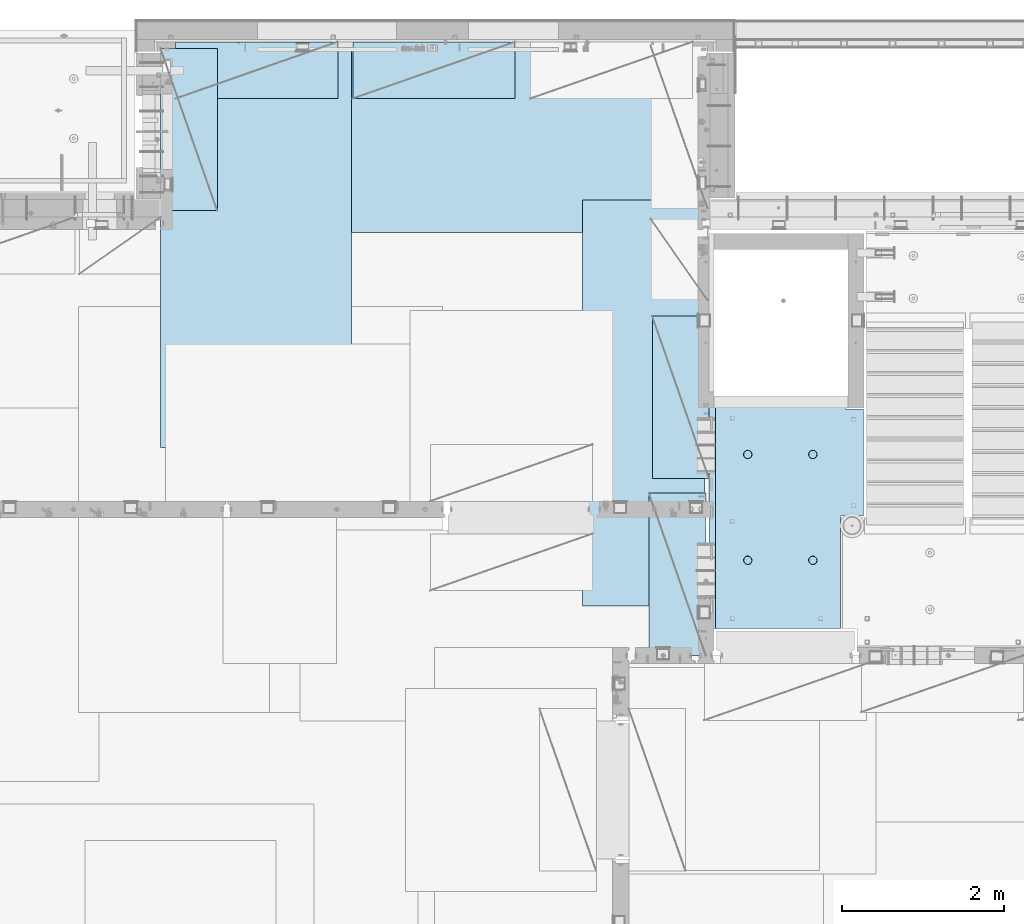
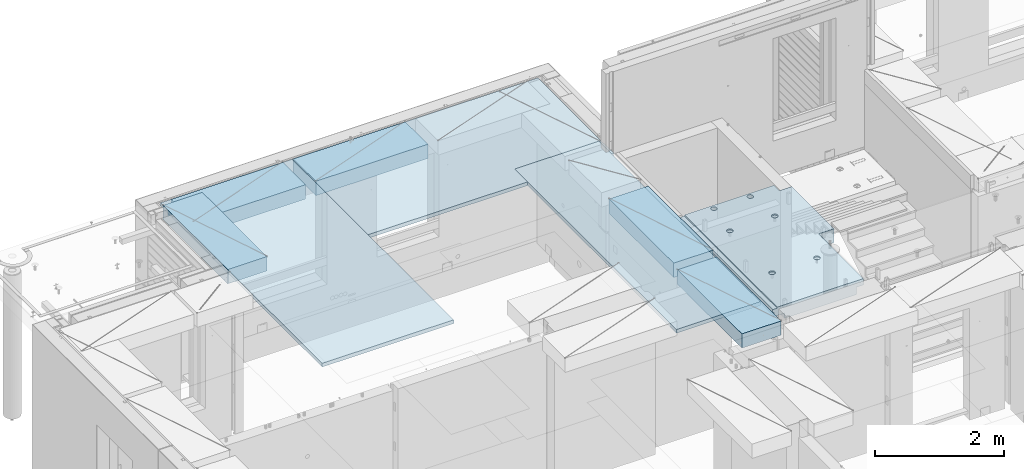
# One storey, part 207 of 350: 8 plates, 1 slab, 9 elements without a shape of their own.
"""IFC2X3 building model written with IfcOpenShell, lengths in millimetres."""

from ifc_helpers import new_model, si_unit, frame, origin_with_axes, place, context, subcontext, project, spatial, faceted_brep, material, type_object, element, aggregate, save


model = new_model("IFC2X3")

# Units and contexts
model_context = context("Model", 3, precision=1e-05, world=origin_with_axes())
body_context = subcontext(model_context, "Body", "Model", "MODEL_VIEW")
ifc_project = project(units=[si_unit("LENGTHUNIT", "METRE", prefix="MILLI"), si_unit("AREAUNIT", "SQUARE_METRE"), si_unit("VOLUMEUNIT", "CUBIC_METRE"), si_unit("MASSUNIT", "GRAM", prefix="KILO"), si_unit("TIMEUNIT", "SECOND"), si_unit("PLANEANGLEUNIT", "RADIAN"), si_unit("SOLIDANGLEUNIT", "STERADIAN"), si_unit("THERMODYNAMICTEMPERATUREUNIT", "DEGREE_CELSIUS"), si_unit("LUMINOUSINTENSITYUNIT", "LUMEN")], contexts=[model_context])

# Site, building, storey
site_placement = place(None, origin_with_axes())
site = spatial("IfcSite", under=ifc_project, at=site_placement, CompositionType="ELEMENT")
building_placement = place(site_placement, origin_with_axes())
building = spatial("IfcBuilding", under=site, at=building_placement, CompositionType="ELEMENT")
storey_placement = place(building_placement, origin_with_axes())
storey = spatial("IfcBuildingStorey", under=building, at=storey_placement, Name="2", CompositionType="ELEMENT", Elevation=0.0)

# Assembly, slab
assembly_1_placement = place(storey_placement, origin_with_axes())
assembly_1 = element("IfcElementAssembly", 1, at=assembly_1_placement, inside=storey, AssemblyPlace="NOTDEFINED", PredefinedType="REINFORCEMENT_UNIT")
ifc_material_1 = material(Name="CONCRETE/C25/30")
slab_type = type_object("IfcSlabType", PredefinedType="NOTDEFINED")
slab_placement = place(assembly_1_placement, frame((19370.0122708302, 15509.9992031236, 87620.0), z_axis=(-0.999999999999509, -9.91000000794397e-07, 0.0), x_axis=(-1.19799915409591e-06, 0.999999999999282, 0.0)))
slab = element("IfcSlab", 2, at=slab_placement, type_object=slab_type, material=ifc_material_1, PredefinedType="FLOOR", context=body_context, shape_type="Brep", body=[
    faceted_brep([(0.00270234311210515, 30.0, 1600.01636881603), (700.003686840937, 30.0, 1600.01632471597), (700.003459213352, 30.0, 1410.0099940095), (0.0034592138545122, 30.0, 1410.0108326095), (700.003459213352, 130.0, 1410.0099940095), (700.003686840937, 50.0008724475629, 1600.01632471597), (700.003710793628, 50.0008724475629, 1620.01159965654), (700.003710793628, 130.0, 1620.01159965654), (0.00238143379829125, 130.0, 1410.01083261132), (2149.99368684227, 30.0, 1600.01623336659), (2149.99345921271, 30.0, 1410.00825692148), (1649.99345921307, 30.0, 1410.00885592148), (1649.99368684195, 30.0, 1600.01626486659), (1390.00354003907, -130.0, -1.24055077321827e-09), (0.0, -130.0, -3.63797880709171e-12), (0.0, -10.0, 0.0), (1390.00503210942, -10.0000000000582, -8.29459168016911e-10), (0.00020267313993827, -10.0000000000582, 119.999691808891), (1390.0049992294, -10.0000000000582, 120.000072670202), (1390.0049992294, 129.999999999942, 120.000072670202), (0.000202673141757259, 130.0, 119.999691808891), (1390.00354003907, 130.0, -1.24055077321827e-09), (1390.00305175782, -130.0, -279.993591308594), (1390.00350516116, 130.0, -19.9999273271205), (1390.00305175782, 130.0, -279.993591308594), (2704.99731446005, 130.0, -279.993808230734), (2704.99731446008, -130.0, -279.993645464809), (2704.99757802008, 130.0, -59.9936454649687), (2704.99757802008, -130.000000000015, -59.9936454649687), (2869.99708830242, -130.0, -59.9938431343799), (2869.99708830242, 130.0, -59.9938431343799), (2869.99538188219, 50.0011350165441, 1600.0161880065), (2869.99536132813, 50.0011350165441, 1620.01123046875), (2149.99371079323, 50.0010478963522, 1620.01135296499), (2149.99368684227, 50.0010478963377, 1600.0162333666), (2869.99536132813, -109.999999999985, 1620.01123046875), (0.00273611420016096, -109.999999999985, 1620.01171875), (0.0026009984267148, -109.999999999985, 1540.01171889739), (2869.99544356416, -109.999999999985, 1540.01180212718), (2869.99536132813, -49.9988649834559, 1620.01123046875), (0.00273611420016096, -49.9992122525582, 1620.01171875), (2869.99538188219, -49.9988649834559, 1600.01618800648), (0.00270234311210515, -49.9992122525582, 1600.01636881602), (2869.99544356416, -129.999999999985, 1540.01180212718), (2869.99536132813, 130.0, 1620.01123046875), (2149.99371079323, 130.0, 1620.01135296499), (2149.99345921271, 130.0, 1410.00825692148), (1649.99345921307, 130.0, 1410.00885592148), (1649.99371079351, 130.0, 1620.01143803163), (1649.99371079351, 50.0009873963572, 1620.01143803163), (1649.99368684195, 50.0009873963427, 1600.0162648666), (0.0026009984267148, -130.0, 1540.01171889739), (858.080152798024, -110.0, 1097.45747495204), (872.018574202059, -110.0, 1104.55943434983), (883.080174557956, -110.0, 1115.62100820216), (890.182167352177, -110.0, 1129.55941258986), (892.62936004754, -110.0, 1145.01025937688), (890.182204372413, -110.0, 1160.46111202734), (883.08024497463, -110.0, 1174.39953343137), (872.018671122296, -110.0, 1185.46113378727), (858.080266734594, -110.0, 1192.56312658148), (842.629419947572, -110.0, 1195.01031927685), (827.178567297122, -110.0, 1192.56316360172), (813.240145893089, -110.0, 1185.46120420394), (802.178545537192, -110.0, 1174.3996303516), (795.076552742968, -110.0, 1160.46122596391), (792.629360047609, -110.0, 1145.01037917688), (795.076515722732, -110.0, 1129.55952652643), (802.178475120518, -110.0, 1115.62110512239), (813.240048972852, -110.0, 1104.5595047665), (827.178453360551, -110.0, 1097.45751197228), (842.629300147573, -110.0, 1095.01031927692), (858.782461559409, -130.0, 1095.29598202818), (842.629297424846, -130.0, 1092.73759200419), (873.354447572716, -130.0, 1102.72075776224), (884.918847944788, -130.0, 1114.28513042604), (892.343658593298, -130.0, 1128.85709864954), (894.902087320264, -130.0, 1145.01025665415), (892.34369729627, -130.0, 1161.16342078871), (884.918921562221, -130.0, 1175.73540680203), (873.354548898418, -130.0, 1187.29980717409), (858.782580674915, -130.0, 1194.72461782261), (842.629422670299, -130.0, 1197.28304654957), (826.476258535738, -130.0, 1194.72465652558), (811.90427252243, -130.0, 1187.29988079152), (800.339872150354, -130.0, 1175.73550812773), (792.915061501848, -130.0, 1161.16353990422), (790.356632774883, -130.0, 1145.01038189961), (792.915022798874, -130.0, 1128.85721776505), (800.339798532925, -130.0, 1114.28523175174), (811.904171196727, -130.0, 1102.72083137967), (826.476139420232, -130.0, 1095.29602073116), (858.08015281103, -110.0, 296.158841760913), (872.018574215066, -110.0, 303.2608011587), (883.080174570961, -110.0, 314.322375011034), (890.182167365187, -110.0, 328.26077939873), (892.629360060546, -110.0, 343.711626185755), (890.182204385423, -110.0, 359.162478836206), (883.080244987636, -110.0, 373.100900240239), (872.018671135302, -110.0, 384.16250059614), (858.0802667476, -110.0, 391.264493390358), (842.62941996058, -110.0, 393.711686085717), (827.178567310128, -110.0, 391.264530410594), (813.240145906095, -110.0, 384.16257101281), (802.178545550198, -110.0, 373.100997160473), (795.076552755974, -110.0, 359.162592772776), (792.629360060615, -110.0, 343.711745985755), (795.076515735738, -110.0, 328.2608933353), (802.178475133525, -110.0, 314.322471931268), (813.240048985859, -110.0, 303.26087157537), (827.178453373557, -110.0, 296.158878781149), (842.629300160579, -110.0, 293.71168608579), (858.782461572417, -130.0, 293.997348837052), (842.629297437852, -130.0, 291.438958813062), (873.354447585723, -130.0, 301.422124571109), (884.918847957797, -130.0, 312.98649723491), (892.343658606304, -130.0, 327.558465458413), (894.90208733327, -130.0, 343.711623463027), (892.343697309276, -130.0, 359.864787597588), (884.918921575227, -130.0, 374.436773610898), (873.354548911424, -130.0, 386.001173982968), (858.782580687921, -130.0, 393.425984631478), (842.629422683307, -130.0, 395.984413358441), (826.476258548744, -130.0, 393.426023334454), (811.904272535436, -130.0, 386.001247600398), (800.339872163362, -130.0, 374.4368749366), (792.915061514856, -130.0, 359.864906713094), (790.356632787889, -130.0, 343.711748708483), (792.915022811882, -130.0, 327.558584573919), (800.339798545931, -130.0, 312.986598560612), (811.904171209735, -130.0, 301.422198188538), (826.47613943324, -130.0, 293.997387540028), (2162.44895919675, -110.0, 1097.45754446905), (2176.38738060079, -110.0, 1104.55950386684), (2187.44898095669, -110.0, 1115.62107771917), (2194.55097375091, -110.0, 1129.55948210687), (2196.99816644627, -110.0, 1145.0103288939), (2194.55101077115, -110.0, 1160.46118154435), (2187.44905137336, -110.0, 1174.39960294838), (2176.38747752102, -110.0, 1185.46120330428), (2162.44907313332, -110.0, 1192.5631960985), (2146.9982263463, -110.0, 1195.01038879386), (2131.54737369585, -110.0, 1192.56323311873), (2117.60895229182, -110.0, 1185.46127372095), (2106.54735193592, -110.0, 1174.39969986862), (2099.4453591417, -110.0, 1160.46129548092), (2096.99816644634, -110.0, 1145.01044869389), (2099.44532212146, -110.0, 1129.55959604344), (2106.54728151925, -110.0, 1115.62117463941), (2117.60885537159, -110.0, 1104.55957428351), (2131.54725975928, -110.0, 1097.45758148929), (2146.9981065463, -110.0, 1095.01038879393), (2163.15126795814, -130.0, 1095.2960515452), (2146.99810382357, -130.0, 1092.73766152121), (2177.72325397145, -130.0, 1102.72082727925), (2189.28765434352, -130.0, 1114.28519994305), (2196.71246499203, -130.0, 1128.85716816655), (2199.27089371899, -130.0, 1145.01032617117), (2196.71250369501, -130.0, 1161.16349030573), (2189.28772796095, -130.0, 1175.73547631904), (2177.72335529715, -130.0, 1187.29987669111), (2163.15138707365, -130.0, 1194.72468733962), (2146.99822906903, -130.0, 1197.28311606658), (2130.84506493447, -130.0, 1194.72472604259), (2116.27307892116, -130.0, 1187.29995030854), (2104.70867854909, -130.0, 1175.73557764474), (2097.28386790058, -130.0, 1161.16360942123), (2094.72543917361, -130.0, 1145.01045141662), (2097.2838291976, -130.0, 1128.85728728206), (2104.70860493166, -130.0, 1114.28530126875), (2116.27297759546, -130.0, 1102.72090089668), (2130.84494581896, -130.0, 1095.29609024817), (2162.44895913772, -110.0, 296.158911320326), (2176.38738054176, -110.0, 303.260870718113), (2187.44898089765, -110.0, 314.322444570447), (2194.55097369188, -110.0, 328.260848958147), (2196.99816638724, -110.0, 343.711695745169), (2194.55101071211, -110.0, 359.162548395623), (2187.44905131433, -110.0, 373.100969799652), (2176.38747746199, -110.0, 384.162570155553), (2162.44907307429, -110.0, 391.264562949771), (2146.99822628727, -110.0, 393.711755645134), (2131.54737363682, -110.0, 391.264599970007), (2117.60895223279, -110.0, 384.162640572227), (2106.54735187689, -110.0, 373.10106671989), (2099.44535908267, -110.0, 359.162662332194), (2096.99816638731, -110.0, 343.711815545168), (2099.44532206243, -110.0, 328.260962894718), (2106.54728146021, -110.0, 314.322541490685), (2117.60885531255, -110.0, 303.260941134788), (2131.54725970025, -110.0, 296.158948340562), (2146.99810648727, -110.0, 293.711755645207), (2163.15126789911, -130.0, 293.997418396466), (2146.99810376454, -130.0, 291.439028372479), (2177.72325391241, -130.0, 301.422194130522), (2189.28765428449, -130.0, 312.986566794323), (2196.712464933, -130.0, 327.558535017826), (2199.27089365996, -130.0, 343.711693022444), (2196.71250363597, -130.0, 359.864857157001), (2189.28772790192, -130.0, 374.436843170311), (2177.72335523811, -130.0, 386.001243542381), (2163.15138701461, -130.0, 393.426054190892), (2146.99822901, -130.0, 395.984482917858), (2130.84506487544, -130.0, 393.426092893867), (2116.27307886213, -130.0, 386.001317159811), (2104.70867849006, -130.0, 374.436944496014), (2097.28386784155, -130.0, 359.864976272507), (2094.72543911458, -130.0, 343.711818267897), (2097.28382913857, -130.0, 327.558654133332), (2104.70860487263, -130.0, 312.986668120026), (2116.27297753642, -130.0, 301.422267747952), (2130.84494575993, -130.0, 293.997457099442), (2805.44844412025, -130.0, 362.453408379821), (2805.44844412025, 130.0, 362.453408379821), (2789.9975914698, 130.0, 360.006252704694), (2789.9975914698, -130.0, 360.006252704694), (2819.38686552428, -130.0, 369.555367777604), (2819.38686552428, 130.0, 369.555367777604), (2830.44846588018, -130.0, 380.616941629942), (2830.44846588018, 130.0, 380.616941629942), (2837.5504586744, -130.0, 394.555346017638), (2837.5504586744, 130.0, 394.555346017638), (2839.99765136976, -130.0, 410.006192804663), (2839.99765136976, 130.0, 410.006192804663), (2837.55049569464, -130.0, 425.457045455114), (2837.55049569464, 130.0, 425.457045455114), (2830.44853629686, -130.0, 439.395466859147), (2830.44853629686, 130.0, 439.395466859147), (2819.38696244451, -130.0, 450.457067215044), (2819.38696244451, 130.0, 450.457067215044), (2805.44855805682, -130.0, 457.559060009266), (2805.44855805682, 130.0, 457.559060009266), (2789.9977112698, -130.0, 460.006252704625), (2789.9977112698, 130.0, 460.006252704625), (2774.54685861935, -130.0, 457.559097029502), (2774.54685861935, 130.0, 457.559097029502), (2760.60843721531, -130.0, 450.457137631718), (2760.60843721531, 130.0, 450.457137631718), (2749.54683685942, -130.0, 439.395563779381), (2749.54683685942, 130.0, 439.395563779381), (2742.44484406519, -130.0, 425.457159391684), (2742.44484406519, 130.0, 425.457159391684), (2739.99765136983, -130.0, 410.006312604663), (2739.99765136983, 130.0, 410.006312604663), (2742.44480704495, -130.0, 394.555459954208), (2742.44480704495, 130.0, 394.555459954208), (2749.54676644274, -130.0, 380.617038550175), (2749.54676644274, 130.0, 380.617038550175), (2760.60834029508, -130.0, 369.555438194278), (2760.60834029508, 130.0, 369.555438194278), (2774.54674468278, -130.0, 362.453445400057), (2774.54674468278, 130.0, 362.453445400057), (2760.60911899507, -130.0, 1019.55543819397), (2749.54754514274, -130.0, 1030.61703854987), (2742.44558574495, -130.0, 1044.5554599539), (2739.99843006983, -130.0, 1060.00631260435), (2742.44562276519, -130.0, 1075.45715939137), (2749.54761555942, -130.0, 1089.39556377907), (2760.60921591531, -130.0, 1100.45713763141), (2774.54763731935, -130.0, 1107.55909702919), (2789.9984899698, -130.0, 1110.00625270432), (2805.44933675682, -130.0, 1107.55906000896), (2819.38774114452, -130.0, 1100.45706721473), (2830.44931499685, -130.0, 1089.39546685884), (2837.55127439463, -130.0, 1075.4570454548), (2839.99843006976, -130.0, 1060.00619280435), (2837.5512373744, -130.0, 1044.55534601733), (2830.44924458018, -130.0, 1030.61694162963), (2819.38764422428, -130.0, 1019.55536777729), (2805.44922282025, -130.0, 1012.45340837951), (2789.9983701698, -130.0, 1010.00625270438), (2774.54752338277, -130.0, 1012.45344539975), (2819.38764422428, 130.0, 1019.55536777729), (2805.44922282025, 130.0, 1012.45340837951), (2830.44924458018, 130.0, 1030.61694162963), (2837.5512373744, 130.0, 1044.55534601733), (2839.99843006976, 130.0, 1060.00619280435), (2837.55127439463, 130.0, 1075.4570454548), (2830.44931499685, 130.0, 1089.39546685884), (2819.38774114452, 130.0, 1100.45706721473), (2805.44933675682, 130.0, 1107.55906000896), (2789.9984899698, 130.0, 1110.00625270432), (2774.54763731935, 130.0, 1107.55909702919), (2760.60921591531, 130.0, 1100.45713763141), (2749.54761555942, 130.0, 1089.39556377907), (2742.44562276519, 130.0, 1075.45715939137), (2739.99843006983, 130.0, 1060.00631260435), (2742.44558574495, 130.0, 1044.5554599539), (2749.54754514274, 130.0, 1030.61703854987), (2760.60911899507, 130.0, 1019.55543819397), (2774.54752338277, 130.0, 1012.45344539975), (2789.9983701698, 130.0, 1010.00625270438)], [[[0, 1, 2, 3]], [[4, 2, 1, 5, 6, 7]], [[8, 3, 2, 4]], [[9, 10, 11, 12]], [[13, 14, 15, 16]], [[15, 17, 18, 16]], [[19, 18, 17, 20]], [[16, 18, 19, 21]], [[22, 13, 16, 21, 23, 24]], [[22, 24, 25, 26]], [[26, 25, 27, 28]], [[29, 28, 27, 30]], [[31, 32, 33, 34]], [[35, 36, 37, 38]], [[36, 35, 39, 40]], [[41, 42, 40, 39]], [[35, 38, 43, 29, 30, 44, 32, 31, 41, 39]], [[32, 44, 45, 33]], [[46, 10, 9, 34, 33, 45]], [[47, 11, 10, 46]], [[48, 49, 50, 12, 11, 47]], [[49, 48, 7, 6]], [[50, 49, 6, 5]], [[42, 41, 31, 34, 9, 12, 50, 5, 1, 0]], [[20, 17, 15, 14, 51, 37, 36, 40, 42, 0, 3, 8]], [[43, 38, 37, 51]], [[52, 53, 54, 55, 56, 57, 58, 59, 60, 61, 62, 63, 64, 65, 66, 67, 68, 69, 70, 71]], [[72, 52, 71, 73]], [[74, 53, 52, 72]], [[75, 54, 53, 74]], [[76, 55, 54, 75]], [[77, 56, 55, 76]], [[78, 57, 56, 77]], [[79, 58, 57, 78]], [[80, 59, 58, 79]], [[81, 60, 59, 80]], [[82, 61, 60, 81]], [[83, 62, 61, 82]], [[84, 63, 62, 83]], [[85, 64, 63, 84]], [[86, 65, 64, 85]], [[87, 66, 65, 86]], [[88, 67, 66, 87]], [[89, 68, 67, 88]], [[90, 69, 68, 89]], [[91, 70, 69, 90]], [[73, 71, 70, 91]], [[92, 93, 94, 95, 96, 97, 98, 99, 100, 101, 102, 103, 104, 105, 106, 107, 108, 109, 110, 111]], [[112, 92, 111, 113]], [[114, 93, 92, 112]], [[115, 94, 93, 114]], [[116, 95, 94, 115]], [[117, 96, 95, 116]], [[118, 97, 96, 117]], [[119, 98, 97, 118]], [[120, 99, 98, 119]], [[121, 100, 99, 120]], [[122, 101, 100, 121]], [[123, 102, 101, 122]], [[124, 103, 102, 123]], [[125, 104, 103, 124]], [[126, 105, 104, 125]], [[127, 106, 105, 126]], [[128, 107, 106, 127]], [[129, 108, 107, 128]], [[130, 109, 108, 129]], [[131, 110, 109, 130]], [[113, 111, 110, 131]], [[132, 133, 134, 135, 136, 137, 138, 139, 140, 141, 142, 143, 144, 145, 146, 147, 148, 149, 150, 151]], [[152, 132, 151, 153]], [[154, 133, 132, 152]], [[155, 134, 133, 154]], [[156, 135, 134, 155]], [[157, 136, 135, 156]], [[158, 137, 136, 157]], [[159, 138, 137, 158]], [[160, 139, 138, 159]], [[161, 140, 139, 160]], [[162, 141, 140, 161]], [[163, 142, 141, 162]], [[164, 143, 142, 163]], [[165, 144, 143, 164]], [[166, 145, 144, 165]], [[167, 146, 145, 166]], [[168, 147, 146, 167]], [[169, 148, 147, 168]], [[170, 149, 148, 169]], [[171, 150, 149, 170]], [[153, 151, 150, 171]], [[172, 173, 174, 175, 176, 177, 178, 179, 180, 181, 182, 183, 184, 185, 186, 187, 188, 189, 190, 191]], [[192, 172, 191, 193]], [[194, 173, 172, 192]], [[195, 174, 173, 194]], [[196, 175, 174, 195]], [[197, 176, 175, 196]], [[198, 177, 176, 197]], [[199, 178, 177, 198]], [[200, 179, 178, 199]], [[201, 180, 179, 200]], [[202, 181, 180, 201]], [[203, 182, 181, 202]], [[204, 183, 182, 203]], [[205, 184, 183, 204]], [[206, 185, 184, 205]], [[207, 186, 185, 206]], [[208, 187, 186, 207]], [[209, 188, 187, 208]], [[210, 189, 188, 209]], [[211, 190, 189, 210]], [[193, 191, 190, 211]], [[212, 213, 214, 215]], [[216, 217, 213, 212]], [[218, 219, 217, 216]], [[220, 221, 219, 218]], [[222, 223, 221, 220]], [[224, 225, 223, 222]], [[226, 227, 225, 224]], [[228, 229, 227, 226]], [[230, 231, 229, 228]], [[232, 233, 231, 230]], [[234, 235, 233, 232]], [[236, 237, 235, 234]], [[238, 239, 237, 236]], [[240, 241, 239, 238]], [[242, 243, 241, 240]], [[244, 245, 243, 242]], [[246, 247, 245, 244]], [[248, 249, 247, 246]], [[250, 251, 249, 248]], [[215, 214, 251, 250]], [[14, 13, 22, 26, 28, 29, 43, 51], [252, 253, 254, 255, 256, 257, 258, 259, 260, 261, 262, 263, 264, 265, 266, 267, 268, 269, 270, 271], [248, 246, 244, 242, 240, 238, 236, 234, 232, 230, 228, 226, 224, 222, 220, 218, 216, 212, 215, 250], [210, 209, 208, 207, 206, 205, 204, 203, 202, 201, 200, 199, 198, 197, 196, 195, 194, 192, 193, 211], [170, 169, 168, 167, 166, 165, 164, 163, 162, 161, 160, 159, 158, 157, 156, 155, 154, 152, 153, 171], [130, 129, 128, 127, 126, 125, 124, 123, 122, 121, 120, 119, 118, 117, 116, 115, 114, 112, 113, 131], [90, 89, 88, 87, 86, 85, 84, 83, 82, 81, 80, 79, 78, 77, 76, 75, 74, 72, 73, 91]], [[268, 272, 273, 269]], [[267, 274, 272, 268]], [[266, 275, 274, 267]], [[265, 276, 275, 266]], [[264, 277, 276, 265]], [[263, 278, 277, 264]], [[262, 279, 278, 263]], [[261, 280, 279, 262]], [[260, 281, 280, 261]], [[259, 282, 281, 260]], [[258, 283, 282, 259]], [[257, 284, 283, 258]], [[256, 285, 284, 257]], [[255, 286, 285, 256]], [[254, 287, 286, 255]], [[253, 288, 287, 254]], [[252, 289, 288, 253]], [[271, 290, 289, 252]], [[270, 291, 290, 271]], [[269, 273, 291, 270]], [[48, 47, 46, 45, 44, 30, 27, 25, 24, 23, 21, 19, 20, 8, 4, 7], [272, 274, 275, 276, 277, 278, 279, 280, 281, 282, 283, 284, 285, 286, 287, 288, 289, 290, 291, 273], [217, 219, 221, 223, 225, 227, 229, 231, 233, 235, 237, 239, 241, 243, 245, 247, 249, 251, 214, 213]]]),
])
aggregate(assembly_1, [slab])

# Assembly, plate
assembly_2_placement = place(storey_placement, origin_with_axes())
assembly_2 = element("IfcElementAssembly", 3, at=assembly_2_placement, inside=storey, Name="Steel Assembly", AssemblyPlace="NOTDEFINED", PredefinedType="NOTDEFINED")
ifc_material_2 = material()
plate_type_1 = type_object("IfcPlateType", PredefinedType="NOTDEFINED")
plate_1_placement = place(assembly_2_placement, frame((12729.9998779297, 22740.0009765625, 87695.1), z_axis=(1.0, 0.0, 0.0), x_axis=(0.0, -1.0, 0.0)))
plate_1 = element("IfcPlate", 4, at=plate_1_placement, type_object=plate_type_1, material=ifc_material_2, context=body_context, shape_type="Brep", body=[
    faceted_brep([(0.0, -35.0, 0.0), (0.0, -35.0, 5000.0), (0.0, 35.0, 5000.0), (0.0, 35.0, 0.0), (2349.99951171875, -35.0, 5000.0), (2349.99951171875, 35.0, 5000.0), (2350.0, -35.0, 0.0), (2350.0, 35.0, 0.0)], [[[0, 1, 2, 3]], [[1, 4, 5, 2]], [[4, 6, 7, 5]], [[6, 0, 3, 7]], [[5, 7, 3, 2]], [[6, 4, 1, 0]]]),
])
aggregate(assembly_2, [plate_1])

assembly_3_placement = place(storey_placement, origin_with_axes())
assembly_3 = element("IfcElementAssembly", 5, at=assembly_3_placement, inside=storey, Name="Steel Assembly", AssemblyPlace="NOTDEFINED", PredefinedType="NOTDEFINED")
plate_2_placement = place(assembly_3_placement, frame((13340.0, 22740.0, 87695.1), z_axis=(0.0, -1.0, 0.0), x_axis=(-1.0, 3.00000001838171e-08, 0.0)))
plate_2 = element("IfcPlate", 6, at=plate_2_placement, type_object=plate_type_1, material=ifc_material_2, context=body_context, shape_type="Brep", body=[
    faceted_brep([(0.0, -35.0, 0.0), (0.0, -35.0, 5000.0), (0.0, 35.0, 5000.0), (0.0, 35.0, 0.0), (2349.99951171875, -35.0, 5000.0), (2349.99951171875, 35.0, 5000.0), (2350.0, -35.0, 0.0), (2350.0, 35.0, 0.0)], [[[0, 1, 2, 3]], [[1, 4, 5, 2]], [[4, 6, 7, 5]], [[6, 0, 3, 7]], [[5, 7, 3, 2]], [[6, 4, 1, 0]]]),
])
aggregate(assembly_3, [plate_2])

assembly_4_placement = place(storey_placement, origin_with_axes())
assembly_4 = element("IfcElementAssembly", 7, at=assembly_4_placement, inside=storey, Name="Steel Assembly", AssemblyPlace="NOTDEFINED", PredefinedType="NOTDEFINED")
plate_type_2 = type_object("IfcPlateType", PredefinedType="NOTDEFINED")
plate_3_placement = place(assembly_4_placement, frame((17690.0000122641, 20790.0, 87695.1000003815), z_axis=(0.0, -1.0, 0.0), x_axis=(-1.0, 3.00000001838171e-08, 0.0)))
plate_3 = element("IfcPlate", 8, at=plate_3_placement, type_object=plate_type_2, material=ifc_material_2, context=body_context, shape_type="Brep", body=[
    faceted_brep([(0.0, -35.0, 0.0), (0.0, -35.0, 5000.0), (0.0, 35.0, 5000.0), (0.0, 35.0, 0.0), (1499.99951171875, -35.0, 5000.0), (1499.99951171875, 35.0, 5000.0), (1500.0, -35.0, 0.0), (1500.0, 35.0, 0.0)], [[[0, 1, 2, 3]], [[1, 4, 5, 2]], [[4, 6, 7, 5]], [[6, 0, 3, 7]], [[5, 7, 3, 2]], [[6, 4, 1, 0]]]),
])
aggregate(assembly_4, [plate_3])

assembly_5_placement = place(storey_placement, origin_with_axes())
assembly_5 = element("IfcElementAssembly", 9, at=assembly_5_placement, inside=storey, Name="Steel Assembly", AssemblyPlace="NOTDEFINED", PredefinedType="NOTDEFINED")
plate_type_3 = type_object("IfcPlateType", PredefinedType="NOTDEFINED")
plate_4_placement = place(assembly_5_placement, frame((17750.0001220703, 17360.0, 87595.3), z_axis=(-1.0, 3.00000001838171e-08, 0.0), x_axis=(0.0, 1.0, 0.0)))
plate_4 = element("IfcPlate", 10, at=plate_4_placement, type_object=plate_type_3, material=ifc_material_2, Name="RE1", context=body_context, shape_type="Brep", body=[
    faceted_brep([(1.81898940354586e-12, -135.0, 1.81898940354586e-12), (0.0, -135.0, 699.999999999996), (0.0, 135.0, 699.999999999996), (1.81898940354586e-12, 135.0, 1.81898940354586e-12), (1999.99951171875, -135.0, 699.999999999993), (1999.99951171875, 135.0, 699.999999999993), (2000.0, -135.0, -3.63797880709171e-12), (2000.0, 135.0, -3.63797880709171e-12)], [[[0, 1, 2, 3]], [[1, 4, 5, 2]], [[4, 6, 7, 5]], [[6, 0, 3, 7]], [[5, 7, 3, 2]], [[6, 4, 1, 0]]]),
])
aggregate(assembly_5, [plate_4])

assembly_6_placement = place(storey_placement, origin_with_axes())
assembly_6 = element("IfcElementAssembly", 11, at=assembly_6_placement, inside=storey, Name="Steel Assembly", AssemblyPlace="NOTDEFINED", PredefinedType="NOTDEFINED")
plate_5_placement = place(assembly_6_placement, frame((17710.0001220703, 15180.0, 87595.3), z_axis=(-1.0, 3.00000001838171e-08, 0.0), x_axis=(0.0, 1.0, 0.0)))
plate_5 = element("IfcPlate", 12, at=plate_5_placement, type_object=plate_type_3, material=ifc_material_2, Name="RE1", context=body_context, shape_type="Brep", body=[
    faceted_brep([(1.81898940354586e-12, -135.0, 1.81898940354586e-12), (0.0, -135.0, 699.999999999996), (0.0, 135.0, 699.999999999996), (1.81898940354586e-12, 135.0, 1.81898940354586e-12), (1999.99951171875, -135.0, 699.999999999993), (1999.99951171875, 135.0, 699.999999999993), (2000.0, -135.0, -3.63797880709171e-12), (2000.0, 135.0, -3.63797880709171e-12)], [[[0, 1, 2, 3]], [[1, 4, 5, 2]], [[4, 6, 7, 5]], [[6, 0, 3, 7]], [[5, 7, 3, 2]], [[6, 4, 1, 0]]]),
])
aggregate(assembly_6, [plate_5])

assembly_7_placement = place(storey_placement, origin_with_axes())
assembly_7 = element("IfcElementAssembly", 13, at=assembly_7_placement, inside=storey, Name="Steel Assembly", AssemblyPlace="NOTDEFINED", PredefinedType="NOTDEFINED")
plate_6_placement = place(assembly_7_placement, frame((13175.0, 22740.0001220703, 87595.3), z_axis=(0.0, -1.0, 0.0), x_axis=(-1.0, 3.00000001838171e-08, 0.0)))
plate_6 = element("IfcPlate", 14, at=plate_6_placement, type_object=plate_type_3, material=ifc_material_2, Name="RE1", context=body_context, shape_type="Brep", body=[
    faceted_brep([(1.81898940354586e-12, -135.0, 1.81898940354586e-12), (0.0, -135.0, 699.999999999996), (0.0, 135.0, 699.999999999996), (1.81898940354586e-12, 135.0, 1.81898940354586e-12), (1999.99951171875, -135.0, 699.999999999993), (1999.99951171875, 135.0, 699.999999999993), (2000.0, -135.0, -3.63797880709171e-12), (2000.0, 135.0, -3.63797880709171e-12)], [[[0, 1, 2, 3]], [[1, 4, 5, 2]], [[4, 6, 7, 5]], [[6, 0, 3, 7]], [[5, 7, 3, 2]], [[6, 4, 1, 0]]]),
])
aggregate(assembly_7, [plate_6])

assembly_8_placement = place(storey_placement, origin_with_axes())
assembly_8 = element("IfcElementAssembly", 15, at=assembly_8_placement, inside=storey, Name="Steel Assembly", AssemblyPlace="NOTDEFINED", PredefinedType="NOTDEFINED")
plate_7_placement = place(assembly_8_placement, frame((15360.0, 22740.0001220703, 87595.3), z_axis=(0.0, -1.0, 0.0), x_axis=(-1.0, 3.00000001838171e-08, 0.0)))
plate_7 = element("IfcPlate", 16, at=plate_7_placement, type_object=plate_type_3, material=ifc_material_2, Name="RE1", context=body_context, shape_type="Brep", body=[
    faceted_brep([(1.81898940354586e-12, -135.0, 1.81898940354586e-12), (0.0, -135.0, 699.999999999996), (0.0, 135.0, 699.999999999996), (1.81898940354586e-12, 135.0, 1.81898940354586e-12), (1999.99951171875, -135.0, 699.999999999993), (1999.99951171875, 135.0, 699.999999999993), (2000.0, -135.0, -3.63797880709171e-12), (2000.0, 135.0, -3.63797880709171e-12)], [[[0, 1, 2, 3]], [[1, 4, 5, 2]], [[4, 6, 7, 5]], [[6, 0, 3, 7]], [[5, 7, 3, 2]], [[6, 4, 1, 0]]]),
])
aggregate(assembly_8, [plate_7])

assembly_9_placement = place(storey_placement, origin_with_axes())
assembly_9 = element("IfcElementAssembly", 17, at=assembly_9_placement, inside=storey, Name="Steel Assembly", AssemblyPlace="NOTDEFINED", PredefinedType="NOTDEFINED")
plate_8_placement = place(assembly_9_placement, frame((10989.9998779297, 22660.0, 87595.3), z_axis=(1.0, 0.0, 0.0), x_axis=(0.0, -1.0, 0.0)))
plate_8 = element("IfcPlate", 18, at=plate_8_placement, type_object=plate_type_3, material=ifc_material_2, Name="RE1", context=body_context, shape_type="Brep", body=[
    faceted_brep([(1.81898940354586e-12, -135.0, 1.81898940354586e-12), (0.0, -135.0, 699.999999999996), (0.0, 135.0, 699.999999999996), (1.81898940354586e-12, 135.0, 1.81898940354586e-12), (1999.99951171875, -135.0, 699.999999999993), (1999.99951171875, 135.0, 699.999999999993), (2000.0, -135.0, -3.63797880709171e-12), (2000.0, 135.0, -3.63797880709171e-12)], [[[0, 1, 2, 3]], [[1, 4, 5, 2]], [[4, 6, 7, 5]], [[6, 0, 3, 7]], [[5, 7, 3, 2]], [[6, 4, 1, 0]]]),
])
aggregate(assembly_9, [plate_8])

save(model, "model.ifc")
